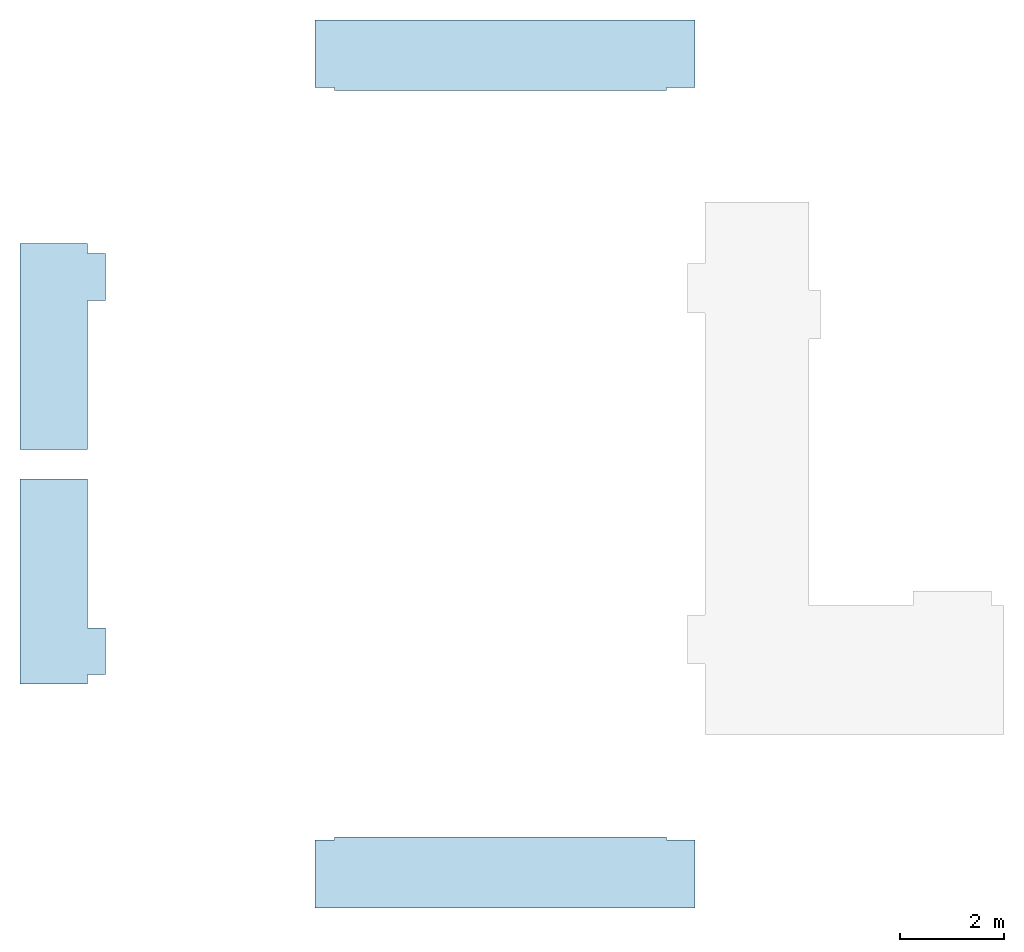
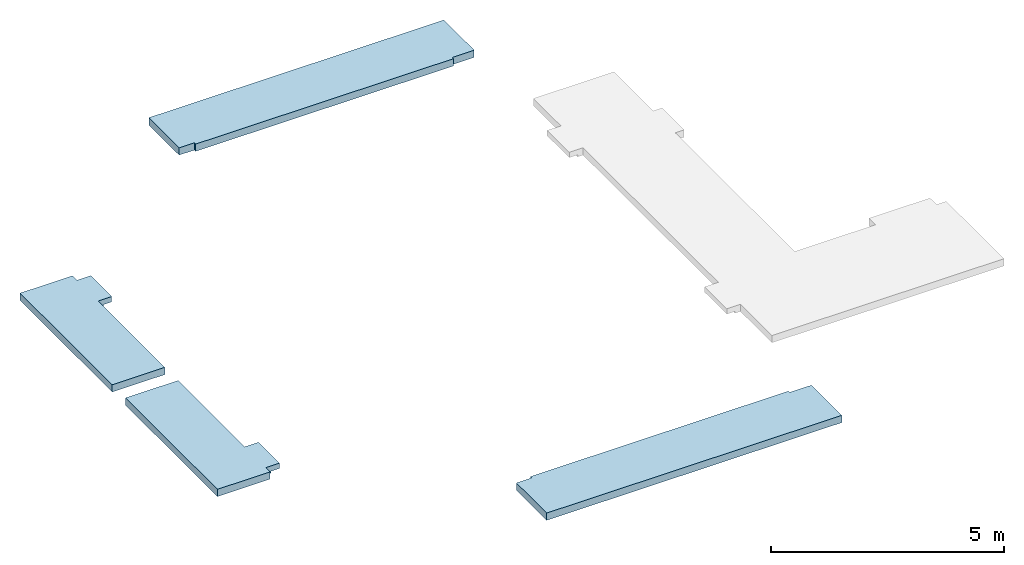
# One storey, part 1 of 2: 4 slabs.
"""IFC2X3 building model written with IfcOpenShell, lengths in millimetres."""

from ifc_helpers import new_model, entity, si_unit, converted_unit, derived_unit, direction, frame, origin, place, context, subcontext, project, spatial, polyline, outline, extrude, faceted_brep, material, layer, layer_set, layer_usage, type_object, element, save


model = new_model("IFC2X3")

# Units and contexts
model_context = context("Model", 3, precision=0.01, world=origin(), true_north=direction((6.12303176911189e-17, 1.0)))
body_context = subcontext(model_context, "Body", "Model", "MODEL_VIEW")
ifc_project = project(units=[si_unit("LENGTHUNIT", "METRE", prefix="MILLI"), si_unit("AREAUNIT", "SQUARE_METRE"), si_unit("VOLUMEUNIT", "CUBIC_METRE"), converted_unit("PLANEANGLEUNIT", "DEGREE", entity("IfcRatioMeasure", 0.0174532925199433), si_unit("PLANEANGLEUNIT", "RADIAN"), dimensions=[0, 0, 0, 0, 0, 0, 0]), si_unit("MASSUNIT", "GRAM", prefix="KILO"), derived_unit("MASSDENSITYUNIT", [(si_unit("MASSUNIT", "GRAM", prefix="KILO"), 1), (si_unit("LENGTHUNIT", "METRE"), -3)]), si_unit("TIMEUNIT", "SECOND"), si_unit("FREQUENCYUNIT", "HERTZ"), si_unit("THERMODYNAMICTEMPERATUREUNIT", "DEGREE_CELSIUS"), derived_unit("THERMALTRANSMITTANCEUNIT", [(si_unit("MASSUNIT", "GRAM", prefix="KILO"), 1), (si_unit("THERMODYNAMICTEMPERATUREUNIT", "KELVIN"), -1), (si_unit("TIMEUNIT", "SECOND"), -3)]), derived_unit("VOLUMETRICFLOWRATEUNIT", [(si_unit("LENGTHUNIT", "METRE"), 3), (si_unit("TIMEUNIT", "SECOND"), -1)]), si_unit("ELECTRICCURRENTUNIT", "AMPERE"), si_unit("ELECTRICVOLTAGEUNIT", "VOLT"), si_unit("POWERUNIT", "WATT"), si_unit("FORCEUNIT", "NEWTON", prefix="KILO"), si_unit("ILLUMINANCEUNIT", "LUX"), si_unit("LUMINOUSFLUXUNIT", "LUMEN"), si_unit("LUMINOUSINTENSITYUNIT", "CANDELA"), derived_unit("USERDEFINED", [(si_unit("MASSUNIT", "GRAM", prefix="KILO"), -1), (si_unit("LENGTHUNIT", "METRE"), -2), (si_unit("TIMEUNIT", "SECOND"), 3), (si_unit("LUMINOUSFLUXUNIT", "LUMEN"), 1)]), derived_unit("LINEARVELOCITYUNIT", [(si_unit("LENGTHUNIT", "METRE"), 1), (si_unit("TIMEUNIT", "SECOND"), -1)]), si_unit("PRESSUREUNIT", "PASCAL"), derived_unit("USERDEFINED", [(si_unit("LENGTHUNIT", "METRE"), -2), (si_unit("MASSUNIT", "GRAM", prefix="KILO"), 1), (si_unit("TIMEUNIT", "SECOND"), -2)])], contexts=[model_context])

# Site, building, storey
site_placement = place(None, origin())
site = spatial("IfcSite", under=ifc_project, at=site_placement, CompositionType="ELEMENT")
building_placement = place(site_placement, origin())
building = spatial("IfcBuilding", under=site, at=building_placement, CompositionType="ELEMENT")
storey_placement = place(building_placement, frame((0.0, 0.0, 4000.0)))
storey = spatial("IfcBuildingStorey", under=building, at=storey_placement, Name="01 Level", CompositionType="ELEMENT", Elevation=4000.0)

# Slabs
slab_type_1 = type_object("IfcSlabType", Name="Floor", PredefinedType="FLOOR")
slab_1_placement = place(storey_placement, origin())
element("IfcSlab", 1, at=slab_1_placement, inside=storey, type_object=slab_type_1, Name="Floor", ObjectType="Floor", PredefinedType="FLOOR", context=body_context, shape_type="Brep", body=[
    faceted_brep([(17043.4900708518, -69121.2395851399, -190.0), (17043.4900708518, -71991.2395851399, -190.0), (17173.4900708518, -71991.2395851399, -190.0), (17173.4900708518, -72891.2395851399, -190.0), (17043.4900708518, -72891.2395851399, -190.0), (17043.4900708518, -73076.2395851399, -190.0), (15738.4900708517, -73076.2395851399, -190.0), (15738.4900708517, -69121.2395851399, -190.0), (17043.4900708518, -71991.2395851399, 0.0), (17043.4900708518, -69121.2395851399, 0.0), (15738.4900708517, -69121.2395851399, 0.0), (15738.4900708517, -73076.2395851399, 0.0), (17043.4900708518, -73076.2395851399, 0.0), (17043.4900708518, -72891.2395851399, 0.0), (17383.4900708533, -72891.2395851399, 0.0), (17383.4900708533, -71991.2395851399, 0.0), (17383.4900708533, -71991.2395851399, -140.0), (17173.4900708518, -71991.2395851399, -140.0), (17383.4900708533, -72891.2395851399, -140.0), (17173.4900708518, -72891.2395851399, -140.0)], [[[0, 1, 2, 3, 4, 5, 6, 7]], [[8, 9, 10, 11, 12, 13, 14, 15]], [[1, 0, 9, 8]], [[6, 5, 12, 11]], [[7, 6, 11, 10]], [[0, 7, 10, 9]], [[8, 15, 16, 17, 2, 1]], [[15, 14, 18, 16]], [[14, 13, 4, 3, 19, 18]], [[5, 4, 13, 12]], [[19, 17, 16, 18]], [[17, 19, 3, 2]]]),
])
ifc_material_1 = material(Name="07")
ifc_layer_1 = layer(ifc_material_1, 15.0)
ifc_material_2 = material(Name="06")
ifc_layer_2 = layer(ifc_material_2, 5.0)
ifc_material_3 = material(Name="02_Beton, C40/55")
ifc_layer_3 = layer(ifc_material_3, 60.0)
ifc_material_4 = material(Name="04_XPS PLUS 30 SF")
ifc_layer_4 = layer(ifc_material_4, 110.0)
ifc_layer_set = layer_set([ifc_layer_1, ifc_layer_2, ifc_layer_3, ifc_layer_4], Name="Floor")
ifc_layer_usage_1 = layer_usage(ifc_layer_set, "AXIS3", "POSITIVE", 0.0)
slab_type_2 = type_object("IfcSlabType", Name="Floor", PredefinedType="FLOOR", material=ifc_layer_set)
slab_2_placement = place(storey_placement, origin())
element("IfcSlab", 2, at=slab_2_placement, inside=storey, type_object=slab_type_2, material=ifc_layer_usage_1, Name="Floor", ObjectType="Floor", PredefinedType="FLOOR", context=body_context, shape_type="SweptSolid", body=[
    extrude(outline(polyline([(-312.499999999979, -3621.25000000001), (992.500000000001, -3621.25000000001), (992.500000000007, 3703.74999999999), (-312.499999999974, 3703.74999999999), (-312.499999999977, 3158.75000000002), (-367.500000000025, 3158.75000000002), (-367.500000000025, -3241.24999999999), (-312.499999999976, -3241.24999999999), (-312.499999999979, -3621.25000000001)])), frame((25044.7400708518, -61268.73958514, 0.0), z_axis=(0.0, 0.0, -1.0), x_axis=(0.0, 1.0, 0.0)), (0.0, 0.0, 1.0), 190.0),
])
ifc_layer_usage_2 = layer_usage(ifc_layer_set, "AXIS3", "POSITIVE", 0.0)
slab_type_3 = type_object("IfcSlabType", Name="Floor", PredefinedType="FLOOR", material=ifc_layer_set)
slab_3_placement = place(storey_placement, origin())
element("IfcSlab", 3, at=slab_3_placement, inside=storey, type_object=slab_type_3, material=ifc_layer_usage_2, Name="Floor", ObjectType="Floor", PredefinedType="FLOOR", context=body_context, shape_type="SweptSolid", body=[
    extrude(outline(polyline([(-992.5, -3621.25000000001), (312.49999999999, -3621.25000000001), (312.49999999999, -3241.24999999999), (367.50000000002, -3241.24999999999), (367.500000000029, 3158.75000000002), (312.49999999999, 3158.75000000002), (312.49999999999, 3703.74999999999), (-992.5, 3703.74999999999), (-992.5, -3621.25000000001)])), frame((25044.7400708518, -76393.7395851399, 0.0), z_axis=(0.0, 0.0, -1.0), x_axis=(0.0, 1.0, 0.0)), (0.0, 0.0, 1.0), 190.0),
])
slab_type_4 = type_object("IfcSlabType", Name="Floor", PredefinedType="FLOOR")
slab_4_placement = place(storey_placement, origin())
element("IfcSlab", 4, at=slab_4_placement, inside=storey, type_object=slab_type_4, Name="Floor", ObjectType="Floor", PredefinedType="FLOOR", context=body_context, shape_type="Brep", body=[
    faceted_brep([(17043.4900708518, -65681.2395851399, -190.0), (17043.4900708518, -68551.2395851399, -190.0), (15738.4900708517, -68551.2395851399, -190.0), (15738.4900708518, -64586.2395851399, -190.0), (17043.4900708518, -64586.2395851399, -190.0), (17043.4900708518, -64781.2395851399, -190.0), (17173.4900708518, -64781.2395851399, -190.0), (17173.4900708518, -65681.2395851399, -190.0), (17043.4900708518, -68551.2395851399, 0.0), (17043.4900708518, -65681.2395851399, 0.0), (17383.4900708533, -65681.2395851399, 0.0), (17383.4900708533, -65671.2395851399, 0.0), (17383.4900708534, -64781.2395851399, 0.0), (17043.4900708518, -64781.2395851399, 0.0), (17043.4900708518, -64586.2395851399, 0.0), (15738.4900708518, -64586.2395851399, 0.0), (15738.4900708517, -68551.2395851399, 0.0), (17173.4900708518, -65681.2395851399, -140.0), (17383.4900708533, -65681.2395851399, -140.0), (17383.4900708533, -65671.2395851399, -140.0), (17383.4900708534, -64781.2395851399, -140.0), (17173.4900708518, -64781.2395851399, -140.0), (17043.4900708518, -64781.2395851399, -140.0)], [[[0, 1, 2, 3, 4, 5, 6, 7]], [[8, 9, 10, 11, 12, 13, 14, 15, 16]], [[1, 0, 9, 8]], [[4, 3, 15, 14]], [[3, 2, 16, 15]], [[2, 1, 8, 16]], [[10, 9, 0, 7, 17, 18]], [[12, 11, 10, 18, 19, 20]], [[13, 12, 20, 21, 6, 5, 22]], [[5, 4, 14, 13, 22]], [[17, 21, 20, 19, 18]], [[21, 17, 7, 6]]]),
])

save(model, "model.ifc")
